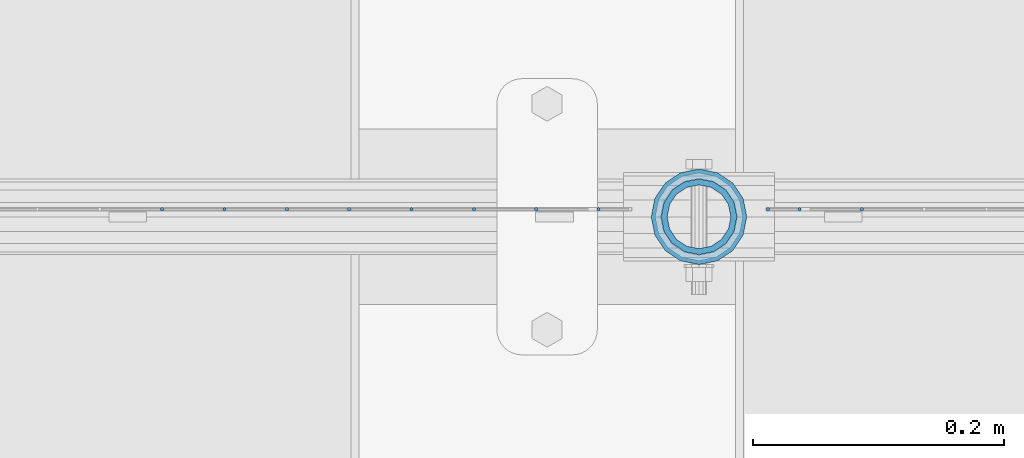
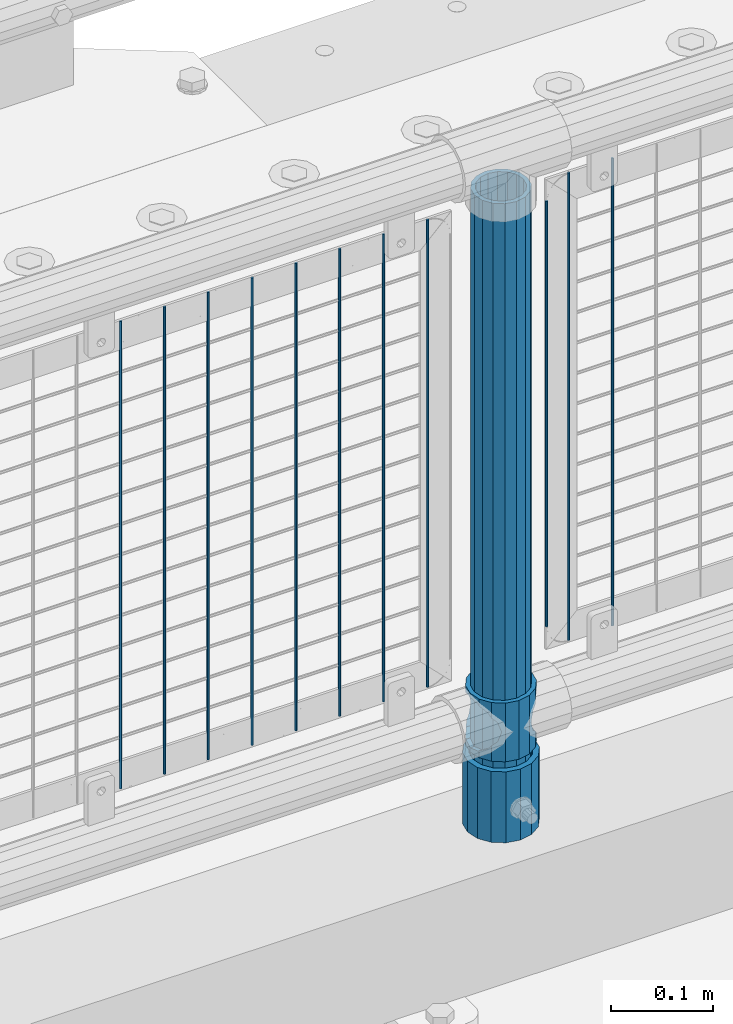
# One storey, part 59 of 208: 14 columns.
"""IFC2X3 building model written with IfcOpenShell, lengths in millimetres."""

from ifc_helpers import new_model, si_unit, frame, origin_with_axes, place, context, subcontext, project, spatial, faceted_brep, material, type_object, element, save


model = new_model("IFC2X3")

# Units and contexts
model_context = context("Model", 3, precision=1e-05, world=origin_with_axes())
body_context = subcontext(model_context, "Body", "Model", "MODEL_VIEW")
ifc_project = project(units=[si_unit("LENGTHUNIT", "METRE", prefix="MILLI"), si_unit("AREAUNIT", "SQUARE_METRE"), si_unit("VOLUMEUNIT", "CUBIC_METRE"), si_unit("MASSUNIT", "GRAM", prefix="KILO"), si_unit("TIMEUNIT", "SECOND"), si_unit("PLANEANGLEUNIT", "RADIAN"), si_unit("SOLIDANGLEUNIT", "STERADIAN"), si_unit("THERMODYNAMICTEMPERATUREUNIT", "DEGREE_CELSIUS"), si_unit("LUMINOUSINTENSITYUNIT", "LUMEN")], contexts=[model_context])

# Site, building, storey
site_placement = place(None, origin_with_axes())
site = spatial("IfcSite", under=ifc_project, at=site_placement, CompositionType="ELEMENT")
building_placement = place(site_placement, origin_with_axes())
building = spatial("IfcBuilding", under=site, at=building_placement, Name="Standard", CompositionType="ELEMENT")
storey_placement = place(building_placement, origin_with_axes())
storey = spatial("IfcBuildingStorey", under=building, at=storey_placement, Name="Undefined", CompositionType="ELEMENT", Elevation=0.0)

# Columns
ifc_material_1 = material()
column_type_1 = type_object("IfcColumnType", PredefinedType="NOTDEFINED")
column_1_placement = place(storey_placement, frame((-38629.0, 4664.5, 168.02), z_axis=(0.0, 1.0, 0.0), x_axis=(0.0, 0.0, 1.0)))
element("IfcColumn", 1, at=column_1_placement, inside=storey, type_object=column_type_1, material=ifc_material_1, context=body_context, shape_type="Brep", body=[
    faceted_brep([(0.0, -31.75, 0.0), (0.0, -29.3331751572332, 12.1501989775916), (85.0, -29.3331751572332, 12.1501989775916), (85.0, -31.75, 0.0), (0.0, -22.4506403026717, 22.4506403026726), (85.0, -22.4506403026717, 22.4506403026726), (0.0, -12.1501989775934, 29.3331751572332), (85.0, -12.1501989775934, 29.3331751572332), (0.0, 0.0, 31.75), (85.0, 0.0, 31.75), (0.0, 12.1501989775934, 29.3331751572332), (85.0, 12.1501989775934, 29.3331751572332), (0.0, 22.4506403026717, 22.4506403026726), (85.0, 22.4506403026717, 22.4506403026726), (0.0, 29.3331751572332, 12.1501989775916), (85.0, 29.3331751572332, 12.1501989775916), (0.0, 31.75, 0.0), (85.0, 31.75, 0.0), (0.0, 29.3331751572332, -12.1501989775916), (85.0, 29.3331751572332, -12.1501989775916), (0.0, 22.4506403026717, -22.4506403026726), (85.0, 22.4506403026717, -22.4506403026726), (0.0, 12.1501989775934, -29.3331751572332), (85.0, 12.1501989775934, -29.3331751572332), (0.0, 0.0, -31.75), (85.0, 0.0, -31.75), (0.0, -12.1501989775934, -29.3331751572332), (85.0, -12.1501989775934, -29.3331751572332), (0.0, -22.4506403026717, -22.4506403026726), (85.0, -22.4506403026717, -22.4506403026726), (0.0, -29.3331751572332, -12.1501989775916), (85.0, -29.3331751572332, -12.1501989775916), (0.0, -38.0499999999993, 0.0), (0.0, -35.1536162120537, -14.5611046014919), (85.0, -35.1536162120537, -14.5611046014919), (85.0, -38.0499999999993, 0.0), (0.0, -26.9054130241493, -26.9054130241484), (85.0, -26.9054130241493, -26.9054130241484), (0.0, -14.5611046014928, -35.1536162120547), (85.0, -14.5611046014928, -35.1536162120547), (0.0, 0.0, -38.0500000000002), (85.0, 0.0, -38.0500000000002), (0.0, 14.5611046014928, -35.1536162120547), (85.0, 14.5611046014928, -35.1536162120547), (0.0, 26.9054130241493, -26.9054130241484), (85.0, 26.9054130241493, -26.9054130241484), (0.0, 35.1536162120537, -14.5611046014919), (85.0, 35.1536162120537, -14.5611046014919), (0.0, 38.0499999999993, 0.0), (85.0, 38.0499999999993, 0.0), (0.0, 35.1536162120537, 14.5611046014919), (85.0, 35.1536162120537, 14.5611046014919), (0.0, 26.9054130241493, 26.9054130241484), (85.0, 26.9054130241493, 26.9054130241484), (0.0, 14.5611046014928, 35.1536162120547), (85.0, 14.5611046014928, 35.1536162120547), (0.0, 0.0, 38.0500000000002), (85.0, 0.0, 38.0500000000002), (0.0, -14.5611046014928, 35.1536162120547), (85.0, -14.5611046014928, 35.1536162120547), (0.0, -26.9054130241493, 26.9054130241484), (85.0, -26.9054130241493, 26.9054130241484), (0.0, -35.1536162120537, 14.5611046014919), (85.0, -35.1536162120537, 14.5611046014919)], [[[0, 1, 2, 3]], [[1, 4, 5, 2]], [[4, 6, 7, 5]], [[6, 8, 9, 7]], [[8, 10, 11, 9]], [[10, 12, 13, 11]], [[12, 14, 15, 13]], [[14, 16, 17, 15]], [[16, 18, 19, 17]], [[18, 20, 21, 19]], [[20, 22, 23, 21]], [[22, 24, 25, 23]], [[24, 26, 27, 25]], [[26, 28, 29, 27]], [[28, 30, 31, 29]], [[30, 0, 3, 31]], [[32, 33, 34, 35]], [[33, 36, 37, 34]], [[36, 38, 39, 37]], [[38, 40, 41, 39]], [[40, 42, 43, 41]], [[42, 44, 45, 43]], [[44, 46, 47, 45]], [[46, 48, 49, 47]], [[48, 50, 51, 49]], [[50, 52, 53, 51]], [[52, 54, 55, 53]], [[54, 56, 57, 55]], [[56, 58, 59, 57]], [[58, 60, 61, 59]], [[60, 62, 63, 61]], [[62, 32, 35, 63]], [[37, 39, 41, 43, 45, 47, 49, 51, 53, 55, 57, 59, 61, 63, 35, 34], [5, 7, 9, 11, 13, 15, 17, 19, 21, 23, 25, 27, 29, 31, 3, 2]], [[62, 60, 58, 56, 54, 52, 50, 48, 46, 44, 42, 40, 38, 36, 33, 32], [30, 28, 26, 24, 22, 20, 18, 16, 14, 12, 10, 8, 6, 4, 1, 0]]]),
])
ifc_material_2 = material(Name="Misc_Undefined")
column_type_2 = type_object("IfcColumnType", PredefinedType="NOTDEFINED")
column_2_placement = place(storey_placement, frame((-38629.0, 4664.5, 263.02), z_axis=(-1.0, 0.0, 0.0), x_axis=(0.0, 0.0, 1.0)))
element("IfcColumn", 2, at=column_2_placement, inside=storey, type_object=column_type_2, material=ifc_material_2, context=body_context, shape_type="Brep", body=[
    faceted_brep([(63.1897438117172, 11.6144421722802, -32.8397438117245), (63.1897438117172, 11.6144421722802, -28.0397438117143), (56.6106908090114, 21.4606908090118, -21.4606908090136), (56.6106908090114, 21.4606908090118, -27.1226768591077), (61.962379517676, 13.4513226476329, -32.4743655677739), (46.7644421722801, 28.0397438117179, -11.6144421722784), (46.7644421722801, 28.0397438117179, -20.0882031229921), (51.531042408003, 24.8548033587067, -24.8548033587067), (35.1500000000015, 30.35, 0.0), (35.1499999999996, 30.3500000000004, -16.6306603983685), (23.5355578277192, 28.0397438117179, -11.6144421722784), (23.5355578277192, 28.0397438117179, -20.0882031229921), (18.7689575919962, 24.8548033587067, -24.8548033587067), (13.6893091909879, 21.4606908090118, -21.4606908090136), (13.6893091909879, 21.4606908090118, -27.1226768591077), (8.33762048232325, 13.4513226476329, -32.4743655677739), (7.11025618828211, 11.6144421722802, -28.0397438117143), (7.11025618828211, 11.6144421722802, -32.8397438117245), (4.79999999999961, 0.0, -30.3499999999985), (4.79999999999961, 0.0, -35.1500000000015), (7.11025618828205, -11.6144421722802, -28.0397438117143), (7.11025618828205, -11.6144421722802, -32.8397438117245), (13.6893091909879, -21.4606908090118, -21.4606908090136), (13.6893091909879, -21.4606908090118, -27.1226768591005), (8.33762048232325, -13.4513226476329, -32.4743655677739), (23.5355578277191, -28.0397438117179, -11.6144421722784), (23.5355578277191, -28.0397438117179, -20.0882031229921), (18.7689575919962, -24.8548033587067, -24.8548033587067), (35.1500000000015, -30.35, 0.0), (35.1499999999996, -30.3500000000004, -16.6306603983685), (46.7644421722801, -28.0397438117179, -11.6144421722784), (46.7644421722801, -28.0397438117179, -20.0882031229921), (51.531042408003, -24.8548033587067, -24.8548033587067), (56.6106908090114, -21.4606908090118, -21.4606908090136), (56.6106908090114, -21.4606908090118, -27.1226768591005), (61.962379517675, -13.4513226476329, -32.4743655677739), (63.1897438117172, -11.6144421722802, -28.0397438117143), (63.1897438117172, -11.6144421722802, -32.8397438117245), (65.4999999999997, 0.0, -30.3499999999985), (65.4999999999997, 0.0, -35.1500000000015), (0.0, -28.0397438117179, -11.6144421722784), (0.0, -30.3500000000004, 0.0), (0.0, -21.4606908090118, -21.4606908090136), (0.0, -11.6144421722802, -28.0397438117143), (0.0, 0.0, -30.3499999999985), (0.0, 11.6144421722802, -28.0397438117143), (0.0, 21.4606908090118, -21.4606908090136), (0.0, 28.0397438117179, -11.6144421722784), (0.0, 30.3500000000004, 0.0), (0.0, 28.0397438117179, 11.6144421722784), (23.5355578277192, 28.0397438117179, 11.6144421722784), (0.0, 21.4606908090118, 21.4606908090136), (13.6893091909879, 21.4606908090118, 21.4606908090136), (0.0, 11.6144421722802, 28.0397438117143), (7.11025618828211, 11.6144421722802, 28.0397438117143), (0.0, 0.0, 30.3499999999985), (4.79999999999961, 0.0, 30.3499999999985), (0.0, -11.6144421722802, 28.0397438117143), (7.11025618828205, -11.6144421722802, 28.0397438117143), (0.0, -21.4606908090118, 21.4606908090136), (13.6893091909879, -21.4606908090118, 21.4606908090136), (0.0, -28.0397438117179, 11.6144421722784), (23.5355578277191, -28.0397438117179, 11.6144421722784), (0.0, -32.4743655677721, 13.4513226476338), (0.0, -35.1499999999996, 0.0), (70.2999999999993, -35.1499999999996, 0.0), (70.2999999999993, -32.4743655677721, 13.4513226476338), (0.0, 13.4513226476329, -32.4743655677739), (0.0, 24.8548033587067, -24.8548033587067), (0.0, 0.0, -35.1499999999996), (0.0, -13.4513226476329, -32.4743655677739), (0.0, -24.8548033587067, -24.8548033587067), (0.0, -24.8548033587067, 24.8548033587067), (0.0, -13.4513226476329, 32.4743655677739), (0.0, 0.0, 35.1499999999996), (0.0, 13.4513226476329, 32.4743655677739), (0.0, 24.8548033587067, 24.8548033587067), (0.0, 32.4743655677721, 13.4513226476338), (0.0, 35.1499999999996, 0.0), (0.0, 32.4743655677721, -13.4513226476338), (0.0, -32.4743655677721, -13.4513226476338), (70.2999999999993, 32.4743655677721, 13.4513226476338), (70.2999999999993, 35.1499999999996, 0.0), (70.2999999999993, 32.4743655677721, -13.4513226476338), (70.2999999999993, 24.8548033587067, -24.8548033587067), (70.2999999999993, 13.4513226476329, -32.4743655677739), (70.2999999999993, 0.0, -35.1500000000015), (70.2999999999993, -13.4513226476329, -32.4743655677739), (70.2999999999993, -24.8548033587067, -24.8548033587067), (70.2999999999993, -32.4743655677721, -13.4513226476338), (70.2999999999993, 28.0397438117179, 11.6144421722784), (70.2999999999993, 21.4606908090118, 21.4606908090136), (56.6106908090114, 21.4606908090118, 21.4606908090136), (46.7644421722801, 28.0397438117179, 11.6144421722784), (70.2999999999993, 11.6144421722802, 28.0397438117143), (63.1897438117172, 11.6144421722802, 28.0397438117143), (70.2999999999993, 0.0, 30.3499999999985), (65.4999999999997, 0.0, 30.3499999999985), (70.2999999999993, -11.6144421722802, 28.0397438117143), (63.1897438117172, -11.6144421722802, 28.0397438117143), (70.2999999999993, -21.4606908090118, 21.4606908090136), (56.6106908090114, -21.4606908090118, 21.4606908090136), (70.2999999999993, -28.0397438117179, 11.6144421722784), (46.7644421722801, -28.0397438117179, 11.6144421722784), (70.2999999999993, -11.6144421722802, -28.0397438117143), (70.2999999999993, 0.0, -30.3499999999985), (70.2999999999993, -21.4606908090118, -21.4606908090136), (70.2999999999993, -28.0397438117179, -11.6144421722784), (70.2999999999993, -30.3500000000004, 0.0), (70.2999999999993, 24.8548033587067, 24.8548033587067), (70.2999999999993, 13.4513226476329, 32.4743655677739), (70.2999999999993, 0.0, 35.1500000000015), (70.2999999999993, -13.4513226476329, 32.4743655677739), (70.2999999999993, -24.8548033587067, 24.8548033587067), (70.2999999999993, 30.3500000000004, 0.0), (70.2999999999993, 28.0397438117179, -11.6144421722784), (70.2999999999993, 21.4606908090118, -21.4606908090136), (70.2999999999993, 11.6144421722802, -28.0397438117143), (61.9623795176756, 13.4513226476329, 32.4743655677739), (51.531042408003, 24.8548033587067, 24.8548033587067), (56.6106908090114, 21.4606908090118, 27.1226768591005), (65.4999999999997, 0.0, 35.1500000000015), (63.1897438117172, 11.6144421722802, 32.8397438117172), (63.1897438117172, -11.6144421722802, 32.8397438117245), (61.962379517675, -13.4513226476329, 32.4743655677739), (56.6106908090114, -21.4606908090118, 27.1226768591077), (51.531042408003, -24.8548033587067, 24.8548033587067), (18.7689575919962, -24.8548033587067, 24.8548033587067), (46.7644421722801, -28.0397438117179, 20.0882031229776), (35.1499999999996, -30.3500000000004, 16.6306603983612), (23.5355578277191, -28.0397438117179, 20.0882031229776), (8.3376204823237, -13.4513226476329, 32.4743655677739), (13.6893091909879, -21.4606908090118, 27.1226768591077), (4.79999999999961, 0.0, 35.1500000000015), (7.11025618828205, -11.6144421722802, 32.8397438117245), (7.11025618828211, 11.6144421722802, 32.8397438117172), (8.3376204823237, 13.4513226476329, 32.4743655677739), (13.6893091909879, 21.4606908090118, 27.1226768591005), (18.7689575919962, 24.8548033587067, 24.8548033587067), (23.5355578277192, 28.0397438117179, 20.0882031229921), (35.1499999999996, 30.3500000000004, 16.6306603983685), (46.7644421722801, 28.0397438117179, 20.0882031229921)], [[[0, 1, 2, 3, 4]], [[3, 2, 5, 6, 7]], [[6, 5, 8, 9]], [[9, 8, 10, 11]], [[12, 11, 10, 13, 14]], [[15, 14, 13, 16, 17]], [[17, 16, 18, 19]], [[19, 18, 20, 21]], [[21, 20, 22, 23, 24]], [[23, 22, 25, 26, 27]], [[26, 25, 28, 29]], [[29, 28, 30, 31]], [[32, 31, 30, 33, 34]], [[35, 34, 33, 36, 37]], [[37, 36, 38, 39]], [[39, 38, 1, 0]], [[40, 41, 28, 25]], [[42, 40, 25, 22]], [[43, 42, 22, 20]], [[44, 43, 20, 18]], [[45, 44, 18, 16]], [[46, 45, 16, 13]], [[47, 46, 13, 10]], [[48, 47, 10, 8]], [[49, 48, 8, 50]], [[51, 49, 50, 52]], [[53, 51, 52, 54]], [[55, 53, 54, 56]], [[57, 55, 56, 58]], [[59, 57, 58, 60]], [[61, 59, 60, 62]], [[41, 61, 62, 28]], [[63, 64, 65, 66]], [[67, 68, 12, 14, 15]], [[69, 67, 15, 17, 19]], [[24, 70, 69, 19, 21]], [[27, 71, 70, 24, 23]], [[63, 72, 73, 74, 75, 76, 77, 78, 79, 68, 67, 69, 70, 71, 80, 64], [40, 42, 43, 44, 45, 46, 47, 48, 49, 51, 53, 55, 57, 59, 61, 41]], [[78, 77, 81, 82]], [[79, 78, 82, 83]], [[9, 11, 12, 68, 79, 83, 84, 7, 6]], [[7, 84, 85, 4, 3]], [[4, 85, 86, 39, 0]], [[87, 88, 32, 34, 35]], [[86, 87, 35, 37, 39]], [[88, 89, 80, 71, 27, 26, 29, 31, 32]], [[64, 80, 89, 65]], [[90, 91, 92, 93]], [[91, 94, 95, 92]], [[94, 96, 97, 95]], [[96, 98, 99, 97]], [[98, 100, 101, 99]], [[100, 102, 103, 101]], [[104, 105, 38, 36]], [[106, 104, 36, 33]], [[107, 106, 33, 30]], [[108, 107, 30, 28]], [[102, 108, 28, 103]], [[88, 87, 86, 85, 84, 83, 82, 81, 109, 110, 111, 112, 113, 66, 65, 89], [100, 98, 96, 94, 91, 90, 114, 115, 116, 117, 105, 104, 106, 107, 108, 102]], [[118, 110, 109, 119, 120]], [[121, 111, 110, 118, 122]], [[112, 111, 121, 123, 124]], [[113, 112, 124, 125, 126]], [[127, 72, 63, 66, 113, 126, 128, 129, 130]], [[131, 73, 72, 127, 132]], [[133, 74, 73, 131, 134]], [[75, 74, 133, 135, 136]], [[76, 75, 136, 137, 138]], [[119, 109, 81, 77, 76, 138, 139, 140, 141]], [[92, 120, 119, 141, 93]], [[95, 122, 118, 120, 92]], [[97, 121, 122, 95]], [[99, 123, 121, 97]], [[101, 125, 124, 123, 99]], [[103, 128, 126, 125, 101]], [[28, 129, 128, 103]], [[62, 130, 129, 28]], [[60, 132, 127, 130, 62]], [[58, 134, 131, 132, 60]], [[56, 133, 134, 58]], [[54, 135, 133, 56]], [[52, 137, 136, 135, 54]], [[50, 139, 138, 137, 52]], [[8, 140, 139, 50]], [[93, 141, 140, 8]], [[114, 90, 93, 8]], [[115, 114, 8, 5]], [[116, 115, 5, 2]], [[117, 116, 2, 1]], [[105, 117, 1, 38]]]),
])
column_type_3 = type_object("IfcColumnType", PredefinedType="NOTDEFINED")
column_3_placement = place(storey_placement, frame((-38629.0, 4664.5, 168.02), z_axis=(-1.0, 0.0, 0.0), x_axis=(0.0, 0.0, 1.0)))
element("IfcColumn", 3, at=column_3_placement, inside=storey, type_object=column_type_3, material=ifc_material_1, context=body_context, shape_type="Brep", body=[
    faceted_brep([(0.0, -25.3500000000004, 0.0), (0.0, -23.4203461491616, 9.70102501045403), (760.0, -23.4203461491616, 9.70102501045403), (760.0, -25.3500000000004, 0.0), (0.0, -17.9251569030794, 17.9251569030785), (760.0, -17.9251569030794, 17.9251569030785), (0.0, -9.70102501045494, 23.4203461491597), (760.0, -9.70102501045494, 23.4203461491597), (0.0, 0.0, 25.3499999999985), (760.0, 0.0, 25.3499999999985), (0.0, 9.70102501045494, 23.4203461491597), (760.0, 9.70102501045494, 23.4203461491597), (0.0, 17.9251569030794, 17.9251569030785), (760.0, 17.9251569030794, 17.9251569030785), (0.0, 23.4203461491616, 9.70102501045403), (760.0, 23.4203461491616, 9.70102501045403), (0.0, 25.3500000000004, 0.0), (760.0, 25.3500000000004, 0.0), (0.0, 23.4203461491616, -9.70102501045403), (760.0, 23.4203461491616, -9.70102501045403), (0.0, 17.9251569030794, -17.9251569030785), (760.0, 17.9251569030794, -17.9251569030785), (0.0, 9.70102501045494, -23.4203461491597), (760.0, 9.70102501045494, -23.4203461491597), (0.0, 0.0, -25.3499999999985), (760.0, 0.0, -25.3499999999985), (0.0, -9.70102501045494, -23.4203461491597), (760.0, -9.70102501045494, -23.4203461491597), (0.0, -17.9251569030794, -17.9251569030785), (760.0, -17.9251569030794, -17.9251569030785), (0.0, -23.4203461491616, -9.70102501045403), (760.0, -23.4203461491616, -9.70102501045403), (0.0, -30.1499999999996, 0.0), (0.0, -27.8549679052148, -11.5379054858058), (760.0, -27.8549679052148, -11.5379054858058), (760.0, -30.1499999999996, 0.0), (0.0, -21.3192694527743, -21.3192694527752), (760.0, -21.3192694527743, -21.3192694527752), (0.0, -11.5379054858076, -27.8549679052157), (760.0, -11.5379054858076, -27.8549679052157), (0.0, 0.0, -30.1500000000015), (760.0, 0.0, -30.1500000000015), (0.0, 11.5379054858076, -27.8549679052157), (760.0, 11.5379054858076, -27.8549679052157), (0.0, 21.3192694527743, -21.3192694527752), (760.0, 21.3192694527743, -21.3192694527752), (0.0, 27.8549679052157, -11.5379054858058), (760.0, 27.8549679052157, -11.5379054858058), (0.0, 30.1499999999996, 0.0), (760.0, 30.1499999999996, 0.0), (0.0, 27.8549679052157, 11.5379054858058), (760.0, 27.8549679052157, 11.5379054858058), (0.0, 21.3192694527743, 21.3192694527752), (760.0, 21.3192694527743, 21.3192694527752), (0.0, 11.5379054858076, 27.8549679052157), (760.0, 11.5379054858076, 27.8549679052157), (0.0, 0.0, 30.1500000000015), (760.0, 0.0, 30.1500000000015), (0.0, -11.5379054858076, 27.8549679052157), (760.0, -11.5379054858076, 27.8549679052157), (0.0, -21.3192694527743, 21.3192694527752), (760.0, -21.3192694527743, 21.3192694527752), (0.0, -27.8549679052157, 11.5379054858058), (760.0, -27.8549679052157, 11.5379054858058)], [[[0, 1, 2, 3]], [[1, 4, 5, 2]], [[4, 6, 7, 5]], [[6, 8, 9, 7]], [[8, 10, 11, 9]], [[10, 12, 13, 11]], [[12, 14, 15, 13]], [[14, 16, 17, 15]], [[16, 18, 19, 17]], [[18, 20, 21, 19]], [[20, 22, 23, 21]], [[22, 24, 25, 23]], [[24, 26, 27, 25]], [[26, 28, 29, 27]], [[28, 30, 31, 29]], [[30, 0, 3, 31]], [[32, 33, 34, 35]], [[33, 36, 37, 34]], [[36, 38, 39, 37]], [[38, 40, 41, 39]], [[40, 42, 43, 41]], [[42, 44, 45, 43]], [[44, 46, 47, 45]], [[46, 48, 49, 47]], [[48, 50, 51, 49]], [[50, 52, 53, 51]], [[52, 54, 55, 53]], [[54, 56, 57, 55]], [[56, 58, 59, 57]], [[58, 60, 61, 59]], [[60, 62, 63, 61]], [[62, 32, 35, 63]], [[37, 39, 41, 43, 45, 47, 49, 51, 53, 55, 57, 59, 61, 63, 35, 34], [5, 7, 9, 11, 13, 15, 17, 19, 21, 23, 25, 27, 29, 31, 3, 2]], [[62, 60, 58, 56, 54, 52, 50, 48, 46, 44, 42, 40, 38, 36, 33, 32], [30, 28, 26, 24, 22, 20, 18, 16, 14, 12, 10, 8, 6, 4, 1, 0]]]),
])
column_type_4 = type_object("IfcColumnType", Name="D3", PredefinedType="NOTDEFINED")
column_4_placement = place(storey_placement, frame((-38499.3448275862, 4670.5, 353.02), z_axis=(-0.999999999962839, 0.0, 8.62099999968473e-06), x_axis=(8.62099999949798e-06, 0.0, 0.999999999962839)))
element("IfcColumn", 4, at=column_4_placement, inside=storey, type_object=column_type_4, material=ifc_material_2, ObjectType="D3", context=body_context, shape_type="Brep", body=[
    faceted_brep([(0.0, -1.49999999999909, 3.63797880709171e-12), (-7.27595761418343e-12, -0.749999999999091, -1.29903810567669), (560.0, -0.75, -1.29903810567703), (560.0, -1.5, 0.0), (-3.63797880709171e-12, 0.750000000000909, -1.29903810567669), (560.0, 0.75, -1.29903810567703), (0.0, 1.50000000000182, 3.63797880709171e-12), (560.0, 1.5, 0.0), (-3.63797880709171e-12, 0.750000000000909, 1.29903810567669), (560.0, 0.75, 1.29903810567703), (-7.27595761418343e-12, -0.749999999999091, 1.29903810567669), (560.0, -0.75, 1.29903810567703)], [[[0, 1, 2, 3]], [[1, 4, 5, 2]], [[4, 6, 7, 5]], [[6, 8, 9, 7]], [[8, 10, 11, 9]], [[10, 0, 3, 11]], [[5, 7, 9, 11, 3, 2]], [[10, 8, 6, 4, 1, 0]]]),
])
column_5_placement = place(storey_placement, frame((-38574.0, 4670.5, 378.02), z_axis=(-1.0, 0.0, 0.0), x_axis=(0.0, 0.0, 1.0)))
element("IfcColumn", 5, at=column_5_placement, inside=storey, type_object=column_type_4, material=ifc_material_2, ObjectType="D3", context=body_context, shape_type="Brep", body=[
    faceted_brep([(0.0, -1.49999999999909, 3.63797880709171e-12), (-7.27595761418343e-12, -0.749999999999091, -1.29903810567669), (510.0, -0.75, -1.29903810567703), (510.0, -1.5, 0.0), (-3.63797880709171e-12, 0.750000000000909, -1.29903810567669), (510.0, 0.75, -1.29903810567703), (0.0, 1.50000000000182, 3.63797880709171e-12), (510.0, 1.5, 0.0), (-3.63797880709171e-12, 0.750000000000909, 1.29903810567669), (510.0, 0.75, 1.29903810567703), (-7.27595761418343e-12, -0.749999999999091, 1.29903810567669), (510.0, -0.75, 1.29903810567703)], [[[0, 1, 2, 3]], [[1, 4, 5, 2]], [[4, 6, 7, 5]], [[6, 8, 9, 7]], [[8, 10, 11, 9]], [[10, 0, 3, 11]], [[5, 7, 9, 11, 3, 2]], [[10, 8, 6, 4, 1, 0]]]),
])
for number, where, z_axis, x_axis in (
    (6, (-38549.0, 4670.5, 353.02), (-1.0, 0.0, 0.0), (0.0, 0.0, 1.0)),
    (7, (-38709.005, 4670.5, 353.02), (-1.0, 0.0, 0.0), (0.0, 0.0, 1.0)),
    (8, (-38758.66, 4670.5, 353.02), (-1.0, 0.0, 0.0), (0.0, 0.0, 1.0)),
    (9, (-38808.315, 4670.5, 353.02), (-1.0, 0.0, 0.0), (0.0, 0.0, 1.0)),
    (10, (-38857.97, 4670.5, 353.02), (-1.0, 0.0, 0.0), (0.0, 0.0, 1.0)),
    (11, (-38907.625, 4670.5, 353.02), (-1.0, 0.0, 0.0), (0.0, 0.0, 1.0)),
    (12, (-38957.28, 4670.5, 353.02), (-1.0, 0.0, 0.0), (0.0, 0.0, 1.0)),
    (13, (-39006.935, 4670.5, 353.02), (-1.0, 0.0, 0.0), (0.0, 0.0, 1.0)),
    (14, (-39056.59, 4670.5, 353.02), (-1.0, 0.0, 0.0), (0.0, 0.0, 1.0)),
):
    element("IfcColumn", number, at=place(storey_placement, frame(where, z_axis=z_axis, x_axis=x_axis)), inside=storey, type_object=column_type_4, material=ifc_material_2, ObjectType="D3", context=body_context, shape_type="Brep", body=[
        faceted_brep([(0.0, -1.49999999999909, 3.63797880709171e-12), (-7.27595761418343e-12, -0.749999999999091, -1.29903810567669), (560.0, -0.75, -1.29903810567703), (560.0, -1.5, 0.0), (-3.63797880709171e-12, 0.750000000000909, -1.29903810567669), (560.0, 0.75, -1.29903810567703), (0.0, 1.50000000000182, 3.63797880709171e-12), (560.0, 1.5, 0.0), (-3.63797880709171e-12, 0.750000000000909, 1.29903810567669), (560.0, 0.75, 1.29903810567703), (-7.27595761418343e-12, -0.749999999999091, 1.29903810567669), (560.0, -0.75, 1.29903810567703)], [[[0, 1, 2, 3]], [[1, 4, 5, 2]], [[4, 6, 7, 5]], [[6, 8, 9, 7]], [[8, 10, 11, 9]], [[10, 0, 3, 11]], [[5, 7, 9, 11, 3, 2]], [[10, 8, 6, 4, 1, 0]]]),
    ])

save(model, "model.ifc")
